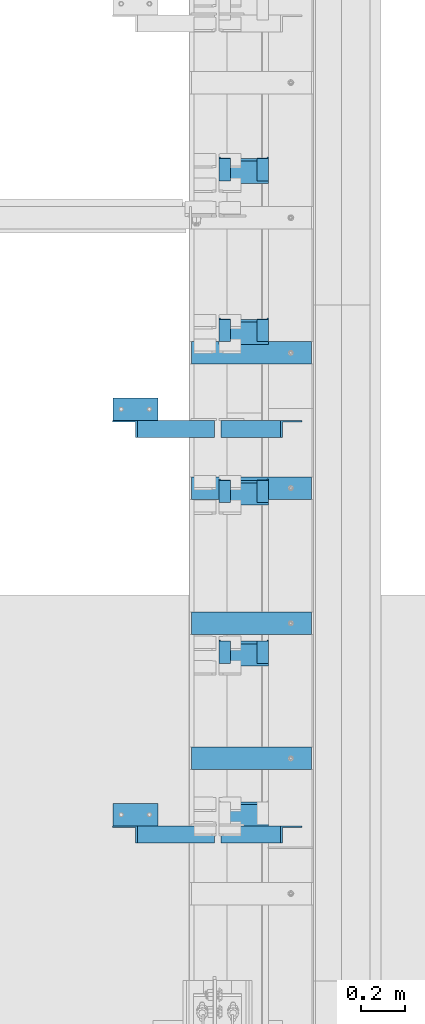
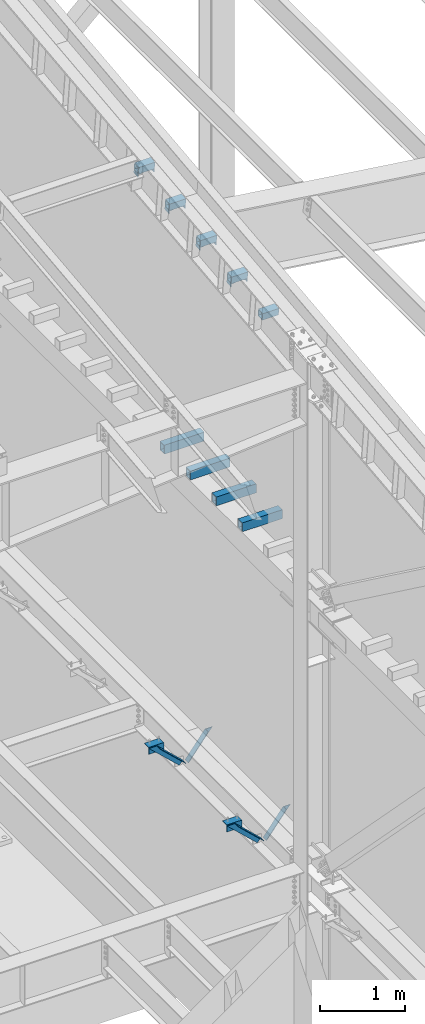
# One storey, part 839 of 1179: 19 beams, 4 members, 17 elements without a shape of their own.
"""IFC2X3 building model written with IfcOpenShell, lengths in millimetres."""

from ifc_helpers import new_model, si_unit, frame, origin_with_axes, place, context, subcontext, project, spatial, faceted_brep, material, type_object, element, aggregate, save


model = new_model("IFC2X3")

# Units and contexts
model_context = context("Model", 3, precision=1e-05, world=origin_with_axes())
body_context = subcontext(model_context, "Body", "Model", "MODEL_VIEW")
ifc_project = project(units=[si_unit("LENGTHUNIT", "METRE", prefix="MILLI"), si_unit("AREAUNIT", "SQUARE_METRE"), si_unit("VOLUMEUNIT", "CUBIC_METRE"), si_unit("MASSUNIT", "GRAM", prefix="KILO"), si_unit("TIMEUNIT", "SECOND"), si_unit("PLANEANGLEUNIT", "RADIAN"), si_unit("SOLIDANGLEUNIT", "STERADIAN"), si_unit("THERMODYNAMICTEMPERATUREUNIT", "DEGREE_CELSIUS"), si_unit("LUMINOUSINTENSITYUNIT", "LUMEN")], contexts=[model_context])

# Site, building, storey
site_placement = place(None, origin_with_axes())
site = spatial("IfcSite", under=ifc_project, at=site_placement, CompositionType="ELEMENT")
building_placement = place(site_placement, origin_with_axes())
building = spatial("IfcBuilding", under=site, at=building_placement, Name="Undefined", CompositionType="ELEMENT")
storey_placement = place(building_placement, origin_with_axes())
storey = spatial("IfcBuildingStorey", under=building, at=storey_placement, Name="Undefined", CompositionType="ELEMENT", Elevation=0.0)

# Assembly, member
assembly_1_placement = place(storey_placement, origin_with_axes())
assembly_1 = element("IfcElementAssembly", 1, at=assembly_1_placement, inside=storey, Name="ANGLE", AssemblyPlace="NOTDEFINED", PredefinedType="RIGID_FRAME")
ifc_material_1 = material(Name="STEEL/A36")
member_type = type_object("IfcMemberType", Name="L3X3X1/4", PredefinedType="NOTDEFINED")
member_1_placement = place(assembly_1_placement, frame((23812.1150890972, 22186.9, 4162.88757791506), z_axis=(0.0, -1.0, 0.0), x_axis=(0.729484494811633, 0.0, -0.683997347823379)))
member_1 = element("IfcMember", 2, at=member_1_placement, type_object=member_type, material=ifc_material_1, Name="ANGLE", ObjectType="L3X3X1/4", context=body_context, shape_type="Brep", body=[
    faceted_brep([(148.072119708857, 38.1000000000204, -38.0999999999985), (148.072119708857, 38.1000000000204, 38.0999999999985), (623.824460863128, 38.1000000000349, 38.0999999999985), (623.824460863128, 38.1000000000349, -38.0999999999985), (141.299832423247, 31.7500000000182, 38.0999999999985), (623.824460863128, 31.7500000000291, 38.0999999999985), (141.299832423247, 31.7500000000182, -31.75), (623.824460863128, 31.7500000000291, -31.75), (66.8046722815307, -38.1000000000095, -31.75), (623.824460863132, -38.0999999999913, -31.75), (66.8046722815307, -38.1000000000095, -38.0999999999985), (623.824460863132, -38.0999999999913, -38.0999999999985)], [[[0, 1, 2, 3]], [[1, 4, 5, 2]], [[4, 6, 7, 5]], [[6, 8, 9, 7]], [[8, 10, 11, 9]], [[10, 0, 3, 11]], [[5, 7, 9, 11, 3, 2]], [[10, 8, 6, 4, 1, 0]]]),
])
aggregate(assembly_1, [member_1])

assembly_2_placement = place(storey_placement, origin_with_axes())
assembly_2 = element("IfcElementAssembly", 3, at=assembly_2_placement, inside=storey, Name="ANGLE", AssemblyPlace="NOTDEFINED", PredefinedType="RIGID_FRAME")
member_2_placement = place(assembly_2_placement, frame((23812.1150890972, 20358.1, 4162.88757791506), z_axis=(0.0, -1.0, 0.0), x_axis=(0.729484494811633, 0.0, -0.683997347823379)))
member_2 = element("IfcMember", 4, at=member_2_placement, type_object=member_type, material=ifc_material_1, Name="ANGLE", ObjectType="L3X3X1/4", context=body_context, shape_type="Brep", body=[
    faceted_brep([(148.072119708857, 38.1000000000204, -38.0999999999985), (148.072119708857, 38.1000000000204, 38.0999999999985), (623.824460863128, 38.1000000000349, 38.0999999999985), (623.824460863128, 38.1000000000349, -38.0999999999985), (141.299832423247, 31.7500000000182, 38.0999999999985), (623.824460863128, 31.7500000000291, 38.0999999999985), (141.299832423247, 31.7500000000182, -31.75), (623.824460863128, 31.7500000000291, -31.75), (66.8046722815307, -38.1000000000095, -31.75), (623.824460863132, -38.0999999999913, -31.75), (66.8046722815307, -38.1000000000095, -38.0999999999985), (623.824460863132, -38.0999999999913, -38.0999999999985)], [[[0, 1, 2, 3]], [[1, 4, 5, 2]], [[4, 6, 7, 5]], [[6, 8, 9, 7]], [[8, 10, 11, 9]], [[10, 0, 3, 11]], [[5, 7, 9, 11, 3, 2]], [[10, 8, 6, 4, 1, 0]]]),
])
aggregate(assembly_2, [member_2])

assembly_3_placement = place(storey_placement, origin_with_axes())
assembly_3 = element("IfcElementAssembly", 5, at=assembly_3_placement, inside=storey, Name="ANGLE", AssemblyPlace="NOTDEFINED", PredefinedType="RIGID_FRAME")
member_3_placement = place(assembly_3_placement, frame((24352.3014298031, 22186.9, 3731.6636484264), z_axis=(0.0, -1.0, 0.0), x_axis=(0.614083067285056, 0.0, 0.789241399366365)))
member_3 = element("IfcMember", 6, at=member_3_placement, type_object=member_type, material=ifc_material_1, Name="ANGLE", ObjectType="L3X3X1/4", context=body_context, shape_type="Brep", body=[
    faceted_brep([(0.0, 38.0999999999985, -38.0999999999999), (0.0, 38.0999999999985, 38.0999999999999), (439.713105507173, 38.1000000000386, 38.0999999999985), (439.713105507173, 38.1000000000386, -38.0999999999985), (0.0, 31.75, 38.1000000000004), (444.653834009747, 31.7500000000473, 38.0999999999985), (0.0, 31.75, -31.75), (444.653834009747, 31.7500000000473, -31.75), (0.0, -38.0999999999985, -31.75), (499.001847538042, -38.0999999998749, -31.75), (0.0, -38.0999999999985, -38.0999999999999), (499.001847538042, -38.0999999998749, -38.0999999999985)], [[[0, 1, 2, 3]], [[1, 4, 5, 2]], [[4, 6, 7, 5]], [[6, 8, 9, 7]], [[8, 10, 11, 9]], [[10, 0, 3, 11]], [[5, 7, 9, 11, 3, 2]], [[10, 8, 6, 4, 1, 0]]]),
])
aggregate(assembly_3, [member_3])

assembly_4_placement = place(storey_placement, origin_with_axes())
assembly_4 = element("IfcElementAssembly", 7, at=assembly_4_placement, inside=storey, Name="ANGLE", AssemblyPlace="NOTDEFINED", PredefinedType="RIGID_FRAME")
member_4_placement = place(assembly_4_placement, frame((24352.3014298031, 20358.1, 3731.6636484264), z_axis=(0.0, -1.0, 0.0), x_axis=(0.614083067285056, 0.0, 0.789241399366365)))
member_4 = element("IfcMember", 8, at=member_4_placement, type_object=member_type, material=ifc_material_1, Name="ANGLE", ObjectType="L3X3X1/4", context=body_context, shape_type="Brep", body=[
    faceted_brep([(0.0, 38.0999999999985, -38.0999999999999), (0.0, 38.0999999999985, 38.0999999999999), (439.713105507173, 38.1000000000386, 38.0999999999985), (439.713105507173, 38.1000000000386, -38.0999999999985), (0.0, 31.75, 38.1000000000004), (444.653834009747, 31.7500000000473, 38.0999999999985), (0.0, 31.75, -31.75), (444.653834009747, 31.7500000000473, -31.75), (0.0, -38.0999999999985, -31.75), (499.001847538042, -38.0999999998749, -31.75), (0.0, -38.0999999999985, -38.0999999999999), (499.001847538042, -38.0999999998749, -38.0999999999985)], [[[0, 1, 2, 3]], [[1, 4, 5, 2]], [[4, 6, 7, 5]], [[6, 8, 9, 7]], [[8, 10, 11, 9]], [[10, 0, 3, 11]], [[5, 7, 9, 11, 3, 2]], [[10, 8, 6, 4, 1, 0]]]),
])
aggregate(assembly_4, [member_4])

# Assembly, beam
assembly_5_placement = place(storey_placement, origin_with_axes())
assembly_5 = element("IfcElementAssembly", 9, at=assembly_5_placement, inside=storey, Name="BEAM", AssemblyPlace="NOTDEFINED", PredefinedType="RIGID_FRAME")
beam_type_1 = type_object("IfcBeamType", Name="L2X2X1/4", PredefinedType="NOTDEFINED")
beam_1_placement = place(assembly_5_placement, frame((24511.0, 23308.9044997641, 11445.9012010156), z_axis=(0.0, 0.112284087038014, -0.993676146336441), x_axis=(0.0, 0.993676146336441, 0.112284087038017)))
beam_1 = element("IfcBeam", 10, at=beam_1_placement, type_object=beam_type_1, material=ifc_material_1, Name="ANGLE", ObjectType="L2X2X1/4", context=body_context, shape_type="Brep", body=[
    faceted_brep([(0.0, 25.3999999999996, -25.4000000000015), (0.0, 25.3999999999996, 25.4000000000015), (101.599999999555, 25.4, 25.3999999999451), (101.599999999537, 25.4, -25.4000000000251), (7.27595761418343e-12, 19.05, 25.3999999999851), (101.599999999555, 19.05, 25.3999999999451), (0.0, 19.0499992350015, -19.0499992349996), (101.600003324515, 19.0499992350051, -19.0499992350015), (-1.09139364212751e-11, -25.4, -19.0499999999865), (101.59999999954, -25.4, -19.0500000000302), (0.0, -25.3999999999996, -25.4000000000015), (101.599999999537, -25.4, -25.4000000000251)], [[[0, 1, 2, 3]], [[1, 4, 5, 2]], [[4, 6, 7, 5]], [[6, 8, 9, 7]], [[8, 10, 11, 9]], [[10, 0, 3, 11]], [[5, 7, 9, 11, 3, 2]], [[10, 8, 6, 4, 1, 0]]]),
])

assembly_6_placement = place(storey_placement, origin_with_axes())
assembly_6 = element("IfcElementAssembly", 11, at=assembly_6_placement, inside=storey, Name="BEAM", AssemblyPlace="NOTDEFINED", PredefinedType="RIGID_FRAME")
beam_2_placement = place(assembly_6_placement, frame((24340.34375, 23308.9044997641, 11445.9012010156), z_axis=(1.0, 0.0, 0.0), x_axis=(0.0, 0.993676146336441, 0.112284087038017)))
beam_2 = element("IfcBeam", 12, at=beam_2_placement, type_object=beam_type_1, material=ifc_material_1, Name="ANGLE", ObjectType="L2X2X1/4", context=body_context, shape_type="Brep", body=[
    faceted_brep([(0.0, 25.3999999999996, -25.4000000000015), (0.0, 25.3999999999996, 25.4000000000015), (101.599999999555, 25.4, 25.3999999999451), (101.599999999537, 25.4, -25.4000000000251), (7.27595761418343e-12, 19.05, 25.3999999999851), (101.599999999555, 19.05, 25.3999999999451), (0.0, 19.0499992350015, -19.0499992349996), (101.600003324515, 19.0499992350051, -19.0499992350015), (-1.09139364212751e-11, -25.4, -19.0499999999865), (101.59999999954, -25.4, -19.0500000000302), (0.0, -25.3999999999996, -25.4000000000015), (101.599999999537, -25.4, -25.4000000000251)], [[[0, 1, 2, 3]], [[1, 4, 5, 2]], [[4, 6, 7, 5]], [[6, 8, 9, 7]], [[8, 10, 11, 9]], [[10, 0, 3, 11]], [[5, 7, 9, 11, 3, 2]], [[10, 8, 6, 4, 1, 0]]]),
])

# Beam
beam_3_placement = place(assembly_5_placement, frame((24511.0, 22583.0068289814, 11363.7946100225), z_axis=(0.0, 0.112284087038014, -0.993676146336441), x_axis=(0.0, 0.993676146336441, 0.112284087038017)))
beam_3 = element("IfcBeam", 13, at=beam_3_placement, type_object=beam_type_1, material=ifc_material_1, Name="ANGLE", ObjectType="L2X2X1/4", context=body_context, shape_type="Brep", body=[
    faceted_brep([(0.0, 25.3999999999996, -25.4000000000015), (0.0, 25.3999999999996, 25.4000000000015), (101.599999999555, 25.4, 25.3999999999451), (101.599999999537, 25.4, -25.4000000000251), (7.27595761418343e-12, 19.05, 25.3999999999851), (101.599999999555, 19.05, 25.3999999999451), (0.0, 19.0499992350015, -19.0499992349996), (101.600003324515, 19.0499992350051, -19.0499992350015), (-1.09139364212751e-11, -25.4, -19.0499999999865), (101.59999999954, -25.4, -19.0500000000302), (0.0, -25.3999999999996, -25.4000000000015), (101.599999999537, -25.4, -25.4000000000251)], [[[0, 1, 2, 3]], [[1, 4, 5, 2]], [[4, 6, 7, 5]], [[6, 8, 9, 7]], [[8, 10, 11, 9]], [[10, 0, 3, 11]], [[5, 7, 9, 11, 3, 2]], [[10, 8, 6, 4, 1, 0]]]),
])

beam_4_placement = place(assembly_6_placement, frame((24340.34375, 22583.0068289814, 11363.7946100225), z_axis=(1.0, 0.0, 0.0), x_axis=(0.0, 0.993676146336441, 0.112284087038017)))
beam_4 = element("IfcBeam", 14, at=beam_4_placement, type_object=beam_type_1, material=ifc_material_1, Name="ANGLE", ObjectType="L2X2X1/4", context=body_context, shape_type="Brep", body=[
    faceted_brep([(0.0, 25.3999999999996, -25.4000000000015), (0.0, 25.3999999999996, 25.4000000000015), (101.599999999555, 25.4, 25.3999999999451), (101.599999999537, 25.4, -25.4000000000251), (7.27595761418343e-12, 19.05, 25.3999999999851), (101.599999999555, 19.05, 25.3999999999451), (0.0, 19.0499992350015, -19.0499992349996), (101.600003324515, 19.0499992350051, -19.0499992350015), (-1.09139364212751e-11, -25.4, -19.0499999999865), (101.59999999954, -25.4, -19.0500000000302), (0.0, -25.3999999999996, -25.4000000000015), (101.599999999537, -25.4, -25.4000000000251)], [[[0, 1, 2, 3]], [[1, 4, 5, 2]], [[4, 6, 7, 5]], [[6, 8, 9, 7]], [[8, 10, 11, 9]], [[10, 0, 3, 11]], [[5, 7, 9, 11, 3, 2]], [[10, 8, 6, 4, 1, 0]]]),
])

beam_5_placement = place(assembly_5_placement, frame((24511.0, 21857.1091581987, 11281.6880190293), z_axis=(0.0, 0.112284087038014, -0.993676146336441), x_axis=(0.0, 0.993676146336441, 0.112284087038017)))
beam_5 = element("IfcBeam", 15, at=beam_5_placement, type_object=beam_type_1, material=ifc_material_1, Name="ANGLE", ObjectType="L2X2X1/4", context=body_context, shape_type="Brep", body=[
    faceted_brep([(0.0, 25.3999999999996, -25.4000000000015), (0.0, 25.3999999999996, 25.4000000000015), (101.599999999555, 25.4, 25.3999999999451), (101.599999999537, 25.4, -25.4000000000251), (7.27595761418343e-12, 19.05, 25.3999999999851), (101.599999999555, 19.05, 25.3999999999451), (0.0, 19.0499992350015, -19.0499992349996), (101.600003324515, 19.0499992350051, -19.0499992350015), (-1.09139364212751e-11, -25.4, -19.0499999999865), (101.59999999954, -25.4, -19.0500000000302), (0.0, -25.3999999999996, -25.4000000000015), (101.599999999537, -25.4, -25.4000000000251)], [[[0, 1, 2, 3]], [[1, 4, 5, 2]], [[4, 6, 7, 5]], [[6, 8, 9, 7]], [[8, 10, 11, 9]], [[10, 0, 3, 11]], [[5, 7, 9, 11, 3, 2]], [[10, 8, 6, 4, 1, 0]]]),
])

beam_6_placement = place(assembly_6_placement, frame((24340.34375, 21857.1091581987, 11281.6880190293), z_axis=(1.0, 0.0, 0.0), x_axis=(0.0, 0.993676146336441, 0.112284087038017)))
beam_6 = element("IfcBeam", 16, at=beam_6_placement, type_object=beam_type_1, material=ifc_material_1, Name="ANGLE", ObjectType="L2X2X1/4", context=body_context, shape_type="Brep", body=[
    faceted_brep([(0.0, 25.3999999999996, -25.4000000000015), (0.0, 25.3999999999996, 25.4000000000015), (101.599999999555, 25.4, 25.3999999999451), (101.599999999537, 25.4, -25.4000000000251), (7.27595761418343e-12, 19.05, 25.3999999999851), (101.599999999555, 19.05, 25.3999999999451), (0.0, 19.0499992350015, -19.0499992349996), (101.600003324515, 19.0499992350051, -19.0499992350015), (-1.09139364212751e-11, -25.4, -19.0499999999865), (101.59999999954, -25.4, -19.0500000000302), (0.0, -25.3999999999996, -25.4000000000015), (101.599999999537, -25.4, -25.4000000000251)], [[[0, 1, 2, 3]], [[1, 4, 5, 2]], [[4, 6, 7, 5]], [[6, 8, 9, 7]], [[8, 10, 11, 9]], [[10, 0, 3, 11]], [[5, 7, 9, 11, 3, 2]], [[10, 8, 6, 4, 1, 0]]]),
])

beam_7_placement = place(assembly_5_placement, frame((24511.0, 21131.2114874161, 11199.5814280361), z_axis=(0.0, 0.112284087038014, -0.993676146336441), x_axis=(0.0, 0.993676146336441, 0.112284087038017)))
beam_7 = element("IfcBeam", 17, at=beam_7_placement, type_object=beam_type_1, material=ifc_material_1, Name="ANGLE", ObjectType="L2X2X1/4", context=body_context, shape_type="Brep", body=[
    faceted_brep([(0.0, 25.3999999999996, -25.4000000000015), (0.0, 25.3999999999996, 25.4000000000015), (101.599999999555, 25.4, 25.3999999999451), (101.599999999537, 25.4, -25.4000000000251), (7.27595761418343e-12, 19.05, 25.3999999999851), (101.599999999555, 19.05, 25.3999999999451), (0.0, 19.0499992350015, -19.0499992349996), (101.600003324515, 19.0499992350051, -19.0499992350015), (-1.09139364212751e-11, -25.4, -19.0499999999865), (101.59999999954, -25.4, -19.0500000000302), (0.0, -25.3999999999996, -25.4000000000015), (101.599999999537, -25.4, -25.4000000000251)], [[[0, 1, 2, 3]], [[1, 4, 5, 2]], [[4, 6, 7, 5]], [[6, 8, 9, 7]], [[8, 10, 11, 9]], [[10, 0, 3, 11]], [[5, 7, 9, 11, 3, 2]], [[10, 8, 6, 4, 1, 0]]]),
])

aggregate(assembly_5, [beam_1, beam_3, beam_5, beam_7])

beam_8_placement = place(assembly_6_placement, frame((24340.34375, 21131.211487416, 11199.5814280361), z_axis=(1.0, 0.0, 0.0), x_axis=(0.0, 0.993676146336441, 0.112284087038017)))
beam_8 = element("IfcBeam", 18, at=beam_8_placement, type_object=beam_type_1, material=ifc_material_1, Name="ANGLE", ObjectType="L2X2X1/4", context=body_context, shape_type="Brep", body=[
    faceted_brep([(0.0, 25.3999999999996, -25.4000000000015), (0.0, 25.3999999999996, 25.4000000000015), (101.599999999555, 25.4, 25.3999999999451), (101.599999999537, 25.4, -25.4000000000251), (7.27595761418343e-12, 19.05, 25.3999999999851), (101.599999999555, 19.05, 25.3999999999451), (0.0, 19.0499992350015, -19.0499992349996), (101.600003324515, 19.0499992350051, -19.0499992350015), (-1.09139364212751e-11, -25.4, -19.0499999999865), (101.59999999954, -25.4, -19.0500000000302), (0.0, -25.3999999999996, -25.4000000000015), (101.599999999537, -25.4, -25.4000000000251)], [[[0, 1, 2, 3]], [[1, 4, 5, 2]], [[4, 6, 7, 5]], [[6, 8, 9, 7]], [[8, 10, 11, 9]], [[10, 0, 3, 11]], [[5, 7, 9, 11, 3, 2]], [[10, 8, 6, 4, 1, 0]]]),
])

aggregate(assembly_6, [beam_2, beam_4, beam_6, beam_8])

# Assembly, beam
assembly_7_placement = place(storey_placement, origin_with_axes())
assembly_7 = element("IfcElementAssembly", 19, at=assembly_7_placement, inside=storey, Name="ANGLE", AssemblyPlace="NOTDEFINED", PredefinedType="RIGID_FRAME")
beam_type_2 = type_object("IfcBeamType", Name="L4X4X1/4", PredefinedType="NOTDEFINED")
beam_9_placement = place(assembly_7_placement, frame((23834.8036446584, 22275.8, 4051.3), z_axis=(0.0, 0.0, -1.0), x_axis=(1.0, 0.0, 0.0)))
beam_9 = element("IfcBeam", 20, at=beam_9_placement, type_object=beam_type_2, material=ifc_material_1, Name="ANGLE", ObjectType="L4X4X1/4", context=body_context, shape_type="Brep", body=[
    faceted_brep([(1.90993887372315e-11, 50.8000000000002, -50.8000000000002), (1.90993887372315e-11, 50.8000000000002, 50.8000000000002), (203.200000000001, 50.7999999999993, 50.8000000000002), (203.200000000001, 50.7999999999993, -50.8000000000002), (0.0, 44.4500000000007, 50.8000000000002), (203.200000000001, 44.4500000000007, 50.8000000000002), (0.0, 44.4500000000007, -44.4499999999998), (203.200000000001, 44.4500000000007, -44.4499999999998), (0.0, -50.7999999999993, -44.4499999999998), (203.200000000001, -50.7999999999993, -44.4499999999998), (-1.81898940354586e-11, -50.7999999999997, -50.8000000000002), (203.200000000001, -50.7999999999993, -50.8000000000002)], [[[0, 1, 2, 3]], [[1, 4, 5, 2]], [[4, 6, 7, 5]], [[6, 8, 9, 7]], [[8, 10, 11, 9]], [[10, 0, 3, 11]], [[5, 7, 9, 11, 3, 2]], [[10, 8, 6, 4, 1, 0]]]),
])
aggregate(assembly_7, [beam_9])

assembly_8_placement = place(storey_placement, origin_with_axes())
assembly_8 = element("IfcElementAssembly", 21, at=assembly_8_placement, inside=storey, Name="ANGLE", AssemblyPlace="NOTDEFINED", PredefinedType="RIGID_FRAME")
beam_10_placement = place(assembly_8_placement, frame((23834.8036446584, 20447.0, 4051.3), z_axis=(0.0, 0.0, -1.0), x_axis=(1.0, 0.0, 0.0)))
beam_10 = element("IfcBeam", 22, at=beam_10_placement, type_object=beam_type_2, material=ifc_material_1, Name="ANGLE", ObjectType="L4X4X1/4", context=body_context, shape_type="Brep", body=[
    faceted_brep([(1.90993887372315e-11, 50.8000000000002, -50.8000000000002), (1.90993887372315e-11, 50.8000000000002, 50.8000000000002), (203.200000000001, 50.7999999999993, 50.8000000000002), (203.200000000001, 50.7999999999993, -50.8000000000002), (0.0, 44.4500000000007, 50.8000000000002), (203.200000000001, 44.4500000000007, 50.8000000000002), (0.0, 44.4500000000007, -44.4499999999998), (203.200000000001, 44.4500000000007, -44.4499999999998), (0.0, -50.7999999999993, -44.4499999999998), (203.200000000001, -50.7999999999993, -44.4499999999998), (-1.81898940354586e-11, -50.7999999999997, -50.8000000000002), (203.200000000001, -50.7999999999993, -50.8000000000002)], [[[0, 1, 2, 3]], [[1, 4, 5, 2]], [[4, 6, 7, 5]], [[6, 8, 9, 7]], [[8, 10, 11, 9]], [[10, 0, 3, 11]], [[5, 7, 9, 11, 3, 2]], [[10, 8, 6, 4, 1, 0]]]),
])
aggregate(assembly_8, [beam_10])

assembly_9_placement = place(storey_placement, origin_with_axes())
assembly_9 = element("IfcElementAssembly", 23, at=assembly_9_placement, inside=storey, Name="BEAM", AssemblyPlace="NOTDEFINED", PredefinedType="RIGID_FRAME")
ifc_material_2 = material()
beam_type_3 = type_object("IfcBeamType", Name="HSS4X4X5/16", PredefinedType="NOTDEFINED")
beam_11_placement = place(assembly_9_placement, frame((24307.8, 21173.1341882175, 11281.0035820083), z_axis=(0.0, -0.112284087038017, 0.993676146336441), x_axis=(1.0, 0.0, 0.0)))
beam_11 = element("IfcBeam", 24, at=beam_11_placement, type_object=beam_type_3, material=ifc_material_2, Name="BEAM", ObjectType="HSS4X4X5/16", context=body_context, shape_type="Brep", body=[
    faceted_brep([(7.14374999999757, 42.8624999999884, -42.8624999999574), (7.14374999999757, -42.8624999999593, -42.862499999992), (228.600000000002, -42.8624999999593, -42.862499999992), (228.600000000002, 42.8624999999884, -42.8624999999574), (7.14374999999757, -42.8624999999956, 42.8624999999611), (228.600000000002, -42.8624999999956, 42.8624999999611), (7.14374999999757, 42.862499999952, 42.8624999999938), (228.600000000002, 42.862499999952, 42.8624999999938), (7.14374999999757, 50.7999999999884, -50.7999999999502), (7.14374999999757, 50.7999999999447, 50.7999999999938), (228.600000000002, 50.7999999999447, 50.7999999999938), (228.600000000002, 50.7999999999884, -50.7999999999502), (7.14374999999757, -50.7999999999956, 50.799999999952), (228.600000000002, -50.7999999999956, 50.799999999952), (7.14374999999757, -50.7999999999556, -50.7999999999902), (228.600000000002, -50.7999999999556, -50.7999999999902)], [[[0, 1, 2, 3]], [[1, 4, 5, 2]], [[4, 6, 7, 5]], [[6, 0, 3, 7]], [[8, 9, 10, 11]], [[9, 12, 13, 10]], [[12, 14, 15, 13]], [[14, 8, 11, 15]], [[13, 15, 11, 10], [5, 7, 3, 2]], [[14, 12, 9, 8], [6, 4, 1, 0]]]),
])
aggregate(assembly_9, [beam_11])

assembly_10_placement = place(storey_placement, origin_with_axes())
assembly_10 = element("IfcElementAssembly", 25, at=assembly_10_placement, inside=storey, Name="BEAM", AssemblyPlace="NOTDEFINED", PredefinedType="RIGID_FRAME")
beam_12_placement = place(assembly_10_placement, frame((24307.8, 21899.0318590002, 11363.1101730015), z_axis=(0.0, -0.112284087038017, 0.993676146336441), x_axis=(1.0, 0.0, 0.0)))
beam_12 = element("IfcBeam", 26, at=beam_12_placement, type_object=beam_type_3, material=ifc_material_2, Name="BEAM", ObjectType="HSS4X4X5/16", context=body_context, shape_type="Brep", body=[
    faceted_brep([(7.14374999999757, 42.8624999999884, -42.8624999999574), (7.14374999999757, -42.8624999999593, -42.862499999992), (228.600000000002, -42.8624999999593, -42.862499999992), (228.600000000002, 42.8624999999884, -42.8624999999574), (7.14374999999757, -42.8624999999956, 42.8624999999611), (228.600000000002, -42.8624999999956, 42.8624999999611), (7.14374999999757, 42.862499999952, 42.8624999999938), (228.600000000002, 42.862499999952, 42.8624999999938), (7.14374999999757, 50.7999999999884, -50.7999999999502), (7.14374999999757, 50.7999999999447, 50.7999999999938), (228.600000000002, 50.7999999999447, 50.7999999999938), (228.600000000002, 50.7999999999884, -50.7999999999502), (7.14374999999757, -50.7999999999956, 50.799999999952), (228.600000000002, -50.7999999999956, 50.799999999952), (7.14374999999757, -50.7999999999556, -50.7999999999902), (228.600000000002, -50.7999999999556, -50.7999999999902)], [[[0, 1, 2, 3]], [[1, 4, 5, 2]], [[4, 6, 7, 5]], [[6, 0, 3, 7]], [[8, 9, 10, 11]], [[9, 12, 13, 10]], [[12, 14, 15, 13]], [[14, 8, 11, 15]], [[13, 15, 11, 10], [5, 7, 3, 2]], [[14, 12, 9, 8], [6, 4, 1, 0]]]),
])
aggregate(assembly_10, [beam_12])

assembly_11_placement = place(storey_placement, origin_with_axes())
assembly_11 = element("IfcElementAssembly", 27, at=assembly_11_placement, inside=storey, Name="BEAM", AssemblyPlace="NOTDEFINED", PredefinedType="RIGID_FRAME")
beam_13_placement = place(assembly_11_placement, frame((24307.8, 22624.9295297829, 11445.2167639946), z_axis=(0.0, -0.112284087038017, 0.993676146336441), x_axis=(1.0, 0.0, 0.0)))
beam_13 = element("IfcBeam", 28, at=beam_13_placement, type_object=beam_type_3, material=ifc_material_2, Name="BEAM", ObjectType="HSS4X4X5/16", context=body_context, shape_type="Brep", body=[
    faceted_brep([(7.14374999999757, 42.8624999999884, -42.8624999999574), (7.14374999999757, -42.8624999999593, -42.862499999992), (228.600000000002, -42.8624999999593, -42.862499999992), (228.600000000002, 42.8624999999884, -42.8624999999574), (7.14374999999757, -42.8624999999956, 42.8624999999611), (228.600000000002, -42.8624999999956, 42.8624999999611), (7.14374999999757, 42.862499999952, 42.8624999999938), (228.600000000002, 42.862499999952, 42.8624999999938), (7.14374999999757, 50.7999999999884, -50.7999999999502), (7.14374999999757, 50.7999999999447, 50.7999999999938), (228.600000000002, 50.7999999999447, 50.7999999999938), (228.600000000002, 50.7999999999884, -50.7999999999502), (7.14374999999757, -50.7999999999956, 50.799999999952), (228.600000000002, -50.7999999999956, 50.799999999952), (7.14374999999757, -50.7999999999556, -50.7999999999902), (228.600000000002, -50.7999999999556, -50.7999999999902)], [[[0, 1, 2, 3]], [[1, 4, 5, 2]], [[4, 6, 7, 5]], [[6, 0, 3, 7]], [[8, 9, 10, 11]], [[9, 12, 13, 10]], [[12, 14, 15, 13]], [[14, 8, 11, 15]], [[13, 15, 11, 10], [5, 7, 3, 2]], [[14, 12, 9, 8], [6, 4, 1, 0]]]),
])
aggregate(assembly_11, [beam_13])

assembly_12_placement = place(storey_placement, origin_with_axes())
assembly_12 = element("IfcElementAssembly", 29, at=assembly_12_placement, inside=storey, Name="BEAM", AssemblyPlace="NOTDEFINED", PredefinedType="RIGID_FRAME")
beam_14_placement = place(assembly_12_placement, frame((24307.8, 23350.8272005656, 11527.3233549878), z_axis=(0.0, -0.112284087038017, 0.993676146336441), x_axis=(1.0, 0.0, 0.0)))
beam_14 = element("IfcBeam", 30, at=beam_14_placement, type_object=beam_type_3, material=ifc_material_2, Name="BEAM", ObjectType="HSS4X4X5/16", context=body_context, shape_type="Brep", body=[
    faceted_brep([(7.14374999999757, 42.8624999999884, -42.8624999999574), (7.14374999999757, -42.8624999999593, -42.862499999992), (228.600000000002, -42.8624999999593, -42.862499999992), (228.600000000002, 42.8624999999884, -42.8624999999574), (7.14374999999757, -42.8624999999956, 42.8624999999611), (228.600000000002, -42.8624999999956, 42.8624999999611), (7.14374999999757, 42.862499999952, 42.8624999999938), (228.600000000002, 42.862499999952, 42.8624999999938), (7.14374999999757, 50.7999999999884, -50.7999999999502), (7.14374999999757, 50.7999999999447, 50.7999999999938), (228.600000000002, 50.7999999999447, 50.7999999999938), (228.600000000002, 50.7999999999884, -50.7999999999502), (7.14374999999757, -50.7999999999956, 50.799999999952), (228.600000000002, -50.7999999999956, 50.799999999952), (7.14374999999757, -50.7999999999556, -50.7999999999902), (228.600000000002, -50.7999999999556, -50.7999999999902)], [[[0, 1, 2, 3]], [[1, 4, 5, 2]], [[4, 6, 7, 5]], [[6, 0, 3, 7]], [[8, 9, 10, 11]], [[9, 12, 13, 10]], [[12, 14, 15, 13]], [[14, 8, 11, 15]], [[13, 15, 11, 10], [5, 7, 3, 2]], [[14, 12, 9, 8], [6, 4, 1, 0]]]),
])
aggregate(assembly_12, [beam_14])

assembly_13_placement = place(storey_placement, origin_with_axes())
assembly_13 = element("IfcElementAssembly", 31, at=assembly_13_placement, inside=storey, Name="BEAM", AssemblyPlace="NOTDEFINED", PredefinedType="RIGID_FRAME")
beam_15_placement = place(assembly_13_placement, frame((24307.8, 20447.2365174349, 11198.8969910152), z_axis=(0.0, -0.112284087038017, 0.993676146336441), x_axis=(1.0, 0.0, 0.0)))
beam_15 = element("IfcBeam", 32, at=beam_15_placement, type_object=beam_type_3, material=ifc_material_2, Name="BEAM", ObjectType="HSS4X4X5/16", context=body_context, shape_type="Brep", body=[
    faceted_brep([(7.14374999999757, 42.8624999999884, -42.8624999999574), (7.14374999999757, -42.8624999999593, -42.862499999992), (228.600000000002, -42.8624999999593, -42.862499999992), (228.600000000002, 42.8624999999884, -42.8624999999574), (7.14374999999757, -42.8624999999956, 42.8624999999611), (228.600000000002, -42.8624999999956, 42.8624999999611), (7.14374999999757, 42.862499999952, 42.8624999999938), (228.600000000002, 42.862499999952, 42.8624999999938), (7.14374999999757, 50.7999999999884, -50.7999999999502), (7.14374999999757, 50.7999999999447, 50.7999999999938), (228.600000000002, 50.7999999999447, 50.7999999999938), (228.600000000002, 50.7999999999884, -50.7999999999502), (7.14374999999757, -50.7999999999956, 50.799999999952), (228.600000000002, -50.7999999999956, 50.799999999952), (7.14374999999757, -50.7999999999556, -50.7999999999902), (228.600000000002, -50.7999999999556, -50.7999999999902)], [[[0, 1, 2, 3]], [[1, 4, 5, 2]], [[4, 6, 7, 5]], [[6, 0, 3, 7]], [[8, 9, 10, 11]], [[9, 12, 13, 10]], [[12, 14, 15, 13]], [[14, 8, 11, 15]], [[13, 15, 11, 10], [5, 7, 3, 2]], [[14, 12, 9, 8], [6, 4, 1, 0]]]),
])
aggregate(assembly_13, [beam_15])

assembly_14_placement = place(storey_placement, origin_with_axes())
assembly_14 = element("IfcElementAssembly", 33, at=assembly_14_placement, inside=storey, Name="BEAM", AssemblyPlace="NOTDEFINED", PredefinedType="RIGID_FRAME")
beam_type_4 = type_object("IfcBeamType", Name="HSS5X4X3/8", PredefinedType="NOTDEFINED")
beam_16_placement = place(assembly_14_placement, frame((24180.8, 22529.8, 8077.19999998781), z_axis=(0.0, 0.0, 1.0), x_axis=(1.0, 0.0, 0.0)))
beam_16 = element("IfcBeam", 34, at=beam_16_placement, type_object=beam_type_4, material=ifc_material_2, Name="BEAM", ObjectType="HSS5X4X3/8", context=body_context, shape_type="Brep", body=[
    faceted_brep([(9.52500000000146, 41.2750000000015, -53.9750000000004), (9.52500000000146, -41.2750000000015, -53.9750000000004), (549.274999999994, -41.2750000000015, -53.9750000000004), (549.274999999994, 41.2750000000015, -53.9750000000004), (9.52500000000146, -41.2750000000015, 53.9750000000004), (549.274999999994, -41.2750000000015, 53.9750000000004), (9.52500000000146, 41.2750000000015, 53.9750000000004), (549.274999999994, 41.2750000000015, 53.9750000000004), (9.52500000000146, 50.7999999999993, -63.5), (9.52500000000146, 50.7999999999993, 63.5), (549.274999999994, 50.7999999999993, 63.5), (549.274999999994, 50.7999999999993, -63.5), (9.52500000000146, -50.7999999999993, 63.5), (549.274999999994, -50.7999999999993, 63.5), (9.52500000000146, -50.7999999999993, -63.5), (549.274999999994, -50.7999999999993, -63.5)], [[[0, 1, 2, 3]], [[1, 4, 5, 2]], [[4, 6, 7, 5]], [[6, 0, 3, 7]], [[8, 9, 10, 11]], [[9, 12, 13, 10]], [[12, 14, 15, 13]], [[14, 8, 11, 15]], [[13, 15, 11, 10], [5, 7, 3, 2]], [[14, 12, 9, 8], [6, 4, 1, 0]]]),
])
aggregate(assembly_14, [beam_16])

assembly_15_placement = place(storey_placement, origin_with_axes())
assembly_15 = element("IfcElementAssembly", 35, at=assembly_15_placement, inside=storey, Name="BEAM", AssemblyPlace="NOTDEFINED", PredefinedType="RIGID_FRAME")
beam_17_placement = place(assembly_15_placement, frame((24180.8, 21920.2, 8077.19999998781), z_axis=(0.0, 0.0, 1.0), x_axis=(1.0, 0.0, 0.0)))
beam_17 = element("IfcBeam", 36, at=beam_17_placement, type_object=beam_type_4, material=ifc_material_2, Name="BEAM", ObjectType="HSS5X4X3/8", context=body_context, shape_type="Brep", body=[
    faceted_brep([(9.52500000000146, 41.2750000000015, -53.9750000000004), (9.52500000000146, -41.2750000000015, -53.9750000000004), (549.274999999994, -41.2750000000015, -53.9750000000004), (549.274999999994, 41.2750000000015, -53.9750000000004), (9.52500000000146, -41.2750000000015, 53.9750000000004), (549.274999999994, -41.2750000000015, 53.9750000000004), (9.52500000000146, 41.2750000000015, 53.9750000000004), (549.274999999994, 41.2750000000015, 53.9750000000004), (9.52500000000146, 50.7999999999993, -63.5), (9.52500000000146, 50.7999999999993, 63.5), (549.274999999994, 50.7999999999993, 63.5), (549.274999999994, 50.7999999999993, -63.5), (9.52500000000146, -50.7999999999993, 63.5), (549.274999999994, -50.7999999999993, 63.5), (9.52500000000146, -50.7999999999993, -63.5), (549.274999999994, -50.7999999999993, -63.5)], [[[0, 1, 2, 3]], [[1, 4, 5, 2]], [[4, 6, 7, 5]], [[6, 0, 3, 7]], [[8, 9, 10, 11]], [[9, 12, 13, 10]], [[12, 14, 15, 13]], [[14, 8, 11, 15]], [[13, 15, 11, 10], [5, 7, 3, 2]], [[14, 12, 9, 8], [6, 4, 1, 0]]]),
])
aggregate(assembly_15, [beam_17])

assembly_16_placement = place(storey_placement, origin_with_axes())
assembly_16 = element("IfcElementAssembly", 37, at=assembly_16_placement, inside=storey, Name="BEAM", AssemblyPlace="NOTDEFINED", PredefinedType="RIGID_FRAME")
beam_18_placement = place(assembly_16_placement, frame((24180.8, 21310.6, 8077.19999998781), z_axis=(0.0, 0.0, 1.0), x_axis=(1.0, 0.0, 0.0)))
beam_18 = element("IfcBeam", 38, at=beam_18_placement, type_object=beam_type_4, material=ifc_material_2, Name="BEAM", ObjectType="HSS5X4X3/8", context=body_context, shape_type="Brep", body=[
    faceted_brep([(9.52500000000146, 41.2750000000015, -53.9750000000004), (9.52500000000146, -41.2750000000015, -53.9750000000004), (549.274999999994, -41.2750000000015, -53.9750000000004), (549.274999999994, 41.2750000000015, -53.9750000000004), (9.52500000000146, -41.2750000000015, 53.9750000000004), (549.274999999994, -41.2750000000015, 53.9750000000004), (9.52500000000146, 41.2750000000015, 53.9750000000004), (549.274999999994, 41.2750000000015, 53.9750000000004), (9.52500000000146, 50.7999999999993, -63.5), (9.52500000000146, 50.7999999999993, 63.5), (549.274999999994, 50.7999999999993, 63.5), (549.274999999994, 50.7999999999993, -63.5), (9.52500000000146, -50.7999999999993, 63.5), (549.274999999994, -50.7999999999993, 63.5), (9.52500000000146, -50.7999999999993, -63.5), (549.274999999994, -50.7999999999993, -63.5)], [[[0, 1, 2, 3]], [[1, 4, 5, 2]], [[4, 6, 7, 5]], [[6, 0, 3, 7]], [[8, 9, 10, 11]], [[9, 12, 13, 10]], [[12, 14, 15, 13]], [[14, 8, 11, 15]], [[13, 15, 11, 10], [5, 7, 3, 2]], [[14, 12, 9, 8], [6, 4, 1, 0]]]),
])
aggregate(assembly_16, [beam_18])

assembly_17_placement = place(storey_placement, origin_with_axes())
assembly_17 = element("IfcElementAssembly", 39, at=assembly_17_placement, inside=storey, Name="BEAM", AssemblyPlace="NOTDEFINED", PredefinedType="RIGID_FRAME")
beam_19_placement = place(assembly_17_placement, frame((24180.8, 20701.0, 8077.19999998781), z_axis=(0.0, 0.0, 1.0), x_axis=(1.0, 0.0, 0.0)))
beam_19 = element("IfcBeam", 40, at=beam_19_placement, type_object=beam_type_4, material=ifc_material_2, Name="BEAM", ObjectType="HSS5X4X3/8", context=body_context, shape_type="Brep", body=[
    faceted_brep([(9.52500000000146, 41.2750000000015, -53.9750000000004), (9.52500000000146, -41.2750000000015, -53.9750000000004), (549.274999999994, -41.2750000000015, -53.9750000000004), (549.274999999994, 41.2750000000015, -53.9750000000004), (9.52500000000146, -41.2750000000015, 53.9750000000004), (549.274999999994, -41.2750000000015, 53.9750000000004), (9.52500000000146, 41.2750000000015, 53.9750000000004), (549.274999999994, 41.2750000000015, 53.9750000000004), (9.52500000000146, 50.7999999999993, -63.5), (9.52500000000146, 50.7999999999993, 63.5), (549.274999999994, 50.7999999999993, 63.5), (549.274999999994, 50.7999999999993, -63.5), (9.52500000000146, -50.7999999999993, 63.5), (549.274999999994, -50.7999999999993, 63.5), (9.52500000000146, -50.7999999999993, -63.5), (549.274999999994, -50.7999999999993, -63.5)], [[[0, 1, 2, 3]], [[1, 4, 5, 2]], [[4, 6, 7, 5]], [[6, 0, 3, 7]], [[8, 9, 10, 11]], [[9, 12, 13, 10]], [[12, 14, 15, 13]], [[14, 8, 11, 15]], [[13, 15, 11, 10], [5, 7, 3, 2]], [[14, 12, 9, 8], [6, 4, 1, 0]]]),
])
aggregate(assembly_17, [beam_19])

save(model, "model.ifc")
